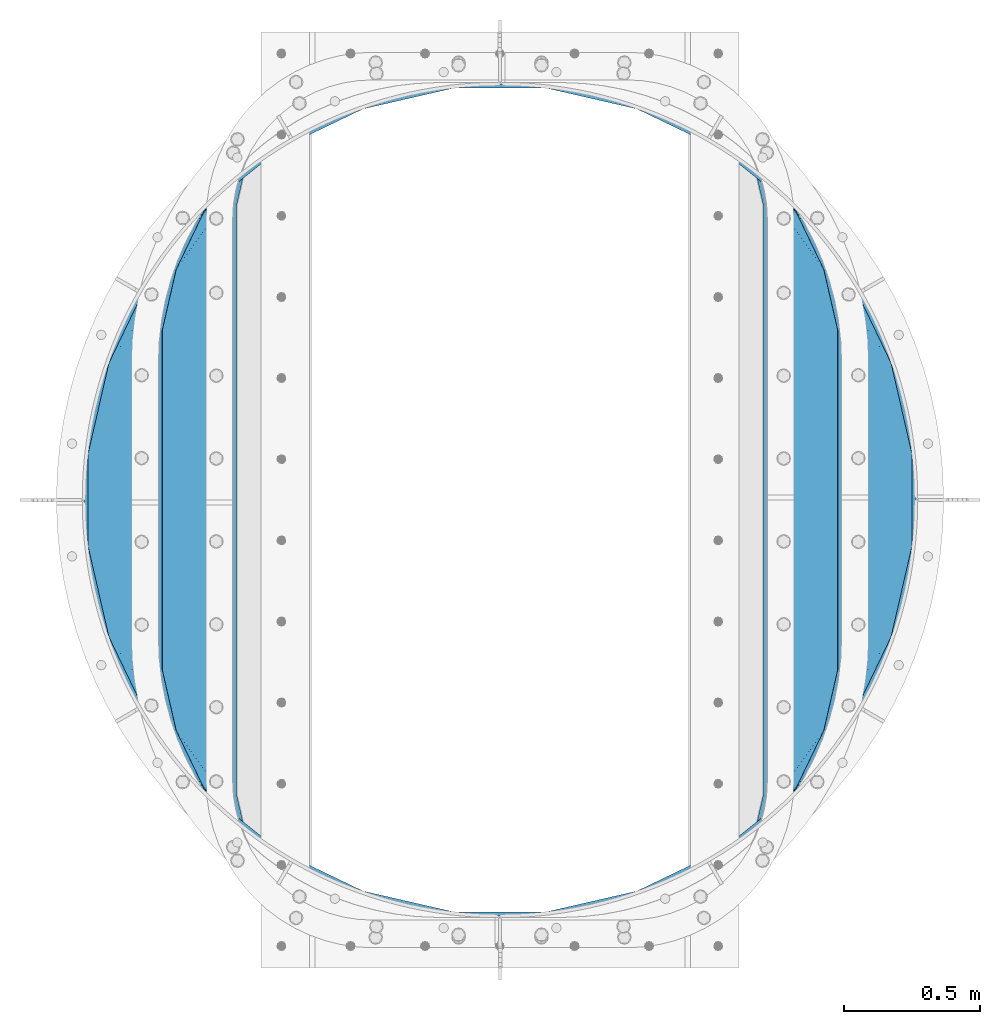
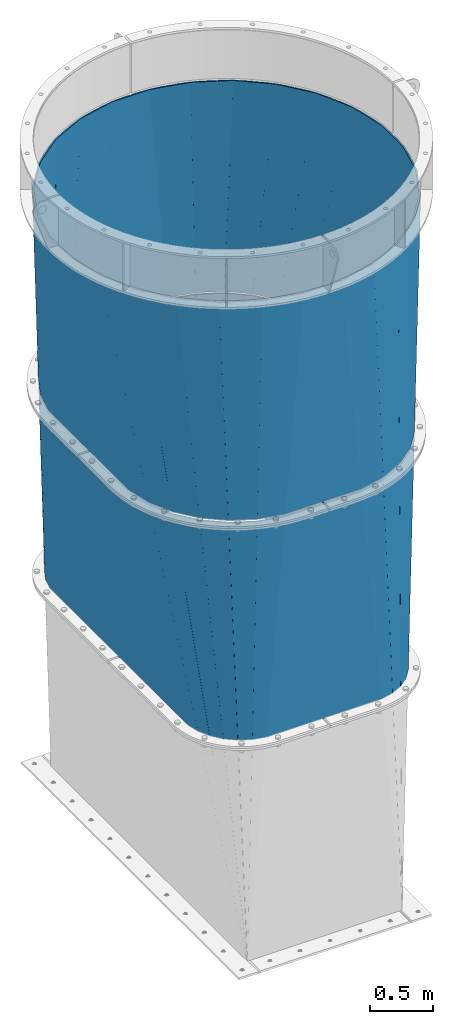
# One storey, part 7 of 15: 2 beams, 2 elements without a shape of their own.
"""IFC2X3 building model written with IfcOpenShell, lengths in millimetres."""

from ifc_helpers import new_model, si_unit, frame, origin_with_axes, place, context, subcontext, project, spatial, faceted_brep, material, type_object, element, aggregate, save


model = new_model("IFC2X3")

# Units and contexts
model_context = context("Model", 3, precision=1e-05, world=origin_with_axes())
body_context = subcontext(model_context, "Body", "Model", "MODEL_VIEW")
ifc_project = project(units=[si_unit("LENGTHUNIT", "METRE", prefix="MILLI"), si_unit("AREAUNIT", "SQUARE_METRE"), si_unit("VOLUMEUNIT", "CUBIC_METRE"), si_unit("MASSUNIT", "GRAM", prefix="KILO"), si_unit("TIMEUNIT", "SECOND"), si_unit("PLANEANGLEUNIT", "RADIAN"), si_unit("SOLIDANGLEUNIT", "STERADIAN"), si_unit("THERMODYNAMICTEMPERATUREUNIT", "DEGREE_CELSIUS"), si_unit("LUMINOUSINTENSITYUNIT", "LUMEN")], contexts=[model_context])

# Site, building, storey
site_placement = place(None, origin_with_axes())
site = spatial("IfcSite", under=ifc_project, at=site_placement, CompositionType="ELEMENT")
building_placement = place(site_placement, origin_with_axes())
building = spatial("IfcBuilding", under=site, at=building_placement, Name="Undefined", CompositionType="ELEMENT")
storey_placement = place(building_placement, origin_with_axes())
storey = spatial("IfcBuildingStorey", under=building, at=storey_placement, Name="Undefined", CompositionType="ELEMENT", Elevation=0.0)

# Assembly, beam
assembly_1_placement = place(storey_placement, origin_with_axes())
assembly_1 = element("IfcElementAssembly", 1, at=assembly_1_placement, inside=storey, Name="TRANSITION", AssemblyPlace="NOTDEFINED", PredefinedType="RIGID_FRAME")
ifc_material = material(Name="STEEL/A36")
beam_type = type_object("IfcBeamType", PredefinedType="NOTDEFINED")
beam_1_placement = place(assembly_1_placement, frame((879.475000000001, 1720.85, 6242.045), z_axis=(1.0, 0.0, 0.0), x_axis=(0.0, 0.0, -1.0)))
beam_1 = element("IfcBeam", 2, at=beam_1_placement, type_object=beam_type, material=ifc_material, Name="TRANSITION", context=body_context, shape_type="Brep", body=[
    faceted_brep([(2069.035, 854.239249285313, 1203.20932660204), (2069.035, 630.620292611843, 1254.49807813265), (4131.73000009537, 1087.72520528114, 982.352835150683), (4131.73000009537, 1200.30381764335, 956.532052498799), (2069.035, 1061.77828739089, 1103.70914863265), (2069.035, 854.571731207215, 1203.20932660204), (4131.73000009537, 1200.96776268595, 956.532052498799), (4131.73000009537, 1305.28372459956, 906.439734154145), (2069.035, 1062.11076931279, 1103.70914863265), (4131.73000009537, 1305.94766964216, 906.439734154145), (2069.035, 1241.62139966993, 960.100644346939), (4131.73000009537, 1396.32040892375, 834.14154272887), (2069.035, 1241.95388159184, 960.100644346939), (4131.73000009537, 1396.98435396635, 834.14154272887), (2069.035, 1385.56238587755, 780.590013989796), (4131.73000009537, 1469.28254539163, 743.768803447277), (2069.035, 1385.56238587755, 779.925050145991), (4131.73000009537, 1469.28254539163, 742.440913362079), (2069.035, 1485.06256384694, 572.718493962317), (4131.73000009537, 1519.37486373628, 638.124951448468), (2069.035, 1485.06256384694, 572.386012040415), (4131.73000009537, 1519.37486373628, 637.461006405869), (2069.035, 1536.35131537755, 348.767055366945), (4131.73000009537, 1545.19564638816, 524.882394043656), (2069.035, 1536.35131537755, -348.767055366945), (4131.73000009537, 1545.19564638816, -524.882394043656), (2069.035, 1485.06256384694, -572.386012040415), (4131.73000009537, 1519.37486373628, -637.461006405869), (2069.035, 1485.06256384694, -573.05097588422), (4131.73000009537, 1519.37486373628, -638.788896491068), (2069.035, 1385.56238587755, -780.257532067893), (4131.73000009537, 1469.28254539163, -743.104858404678), (2069.035, 1385.56238587755, -780.590013989796), (4131.73000009537, 1469.28254539163, -743.768803447277), (2069.035, 1241.95388159184, -960.100644346939), (4131.73000009537, 1396.98435396635, -834.14154272887), (2069.035, 1241.62139966993, -960.100644346939), (4131.73000009537, 1396.32040892375, -834.14154272887), (2069.035, 1062.11076931279, -1103.70914863265), (4131.73000009537, 1305.94766964216, -906.439734154145), (2069.035, 1061.77828739089, -1103.70914863265), (4131.73000009537, 1305.28372459956, -906.439734154145), (2069.035, 854.571731207215, -1203.20932660204), (4131.73000009537, 1200.96776268595, -956.532052498799), (2069.035, 854.239249285313, -1203.20932660204), (4131.73000009537, 1200.30381764335, -956.532052498799), (2069.035, 630.620292611843, -1254.49807813265), (4131.73000009537, 1087.72520528114, -982.352835150683), (2069.035, -630.620292611843, -1254.49807813265), (4131.73000009537, -1087.72520528114, -982.352835150683), (2069.035, -854.239249285313, -1203.20932660204), (4131.73000009537, -1200.30381764335, -956.532052498799), (2069.035, -854.571731207215, -1203.20932660204), (4131.73000009537, -1200.96776268595, -956.532052498799), (2069.035, -1061.77828739089, -1103.70914863265), (4131.73000009537, -1305.28372459956, -906.439734154145), (2069.035, -1062.11076931279, -1103.70914863265), (4131.73000009537, -1305.94766964216, -906.439734154145), (2069.035, -1241.62139966993, -960.100644346939), (4131.73000009537, -1396.32040892375, -834.14154272887), (2069.035, -1241.95388159184, -960.100644346939), (4131.73000009537, -1396.98435396635, -834.14154272887), (2069.035, -1385.56238587755, -780.590013989796), (4131.73000009537, -1469.28254539163, -743.768803447277), (2069.035, -1385.56238587755, -779.925050145991), (4131.73000009537, -1469.28254539163, -742.440913362079), (2069.035, -1485.06256384694, -572.718493962317), (4131.73000009537, -1519.37486373628, -638.124951448468), (2069.035, -1485.06256384694, -572.386012040415), (4131.73000009537, -1519.37486373628, -637.461006405869), (2069.035, -1536.35131537755, -348.767055366945), (4131.73000009537, -1545.19564638816, -524.882394043656), (2069.035, -1536.35131537755, 348.767055366945), (4131.73000009537, -1545.19564638816, 524.882394043656), (2069.035, -1485.06256384694, 572.386012040415), (4131.73000009537, -1519.37486373628, 637.461006405869), (2069.035, -1485.06256384694, 573.05097588422), (4131.73000009537, -1519.37486373628, 638.788896491068), (2069.035, -1385.56238587755, 780.257532067893), (4131.73000009537, -1469.28254539163, 743.104858404678), (2069.035, -1385.56238587755, 780.590013989796), (4131.73000009537, -1469.28254539163, 743.768803447277), (2069.035, -1241.95388159184, 960.100644346939), (4131.73000009537, -1396.98435396635, 834.14154272887), (2069.035, -1241.62139966993, 960.100644346939), (4131.73000009537, -1396.32040892375, 834.14154272887), (2069.035, -1062.11076931279, 1103.70914863265), (4131.73000009537, -1305.94766964216, 906.439734154145), (2069.035, -1061.77828739089, 1103.70914863265), (4131.73000009537, -1305.28372459956, 906.439734154145), (2069.035, -854.571731207215, 1203.20932660204), (4131.73000009537, -1200.96776268595, 956.532052498799), (2069.035, -854.239249285313, 1203.20932660204), (4131.73000009537, -1200.30381764335, 956.532052498799), (2069.035, -630.620292611843, 1254.49807813265), (4131.73000009537, -1087.72520528114, 982.352835150683), (2069.035, -847.551642533746, 1190.98406545918), (2069.035, -1053.04574783987, 1092.3062030102), (2069.035, -1053.37822976177, 1092.3062030102), (2069.035, -1231.40530119034, 949.884545867347), (2069.035, -1231.73778311224, 949.884545867347), (2069.035, -1374.1594402551, 771.857474438776), (2069.035, -1374.1594402551, 771.19251059497), (2069.035, -1472.83730270408, 565.698405288848), (2069.035, -1472.83730270408, 565.365923366945), (2069.035, -1523.7021802551, 343.595057244496), (2069.035, -1523.7021802551, -343.595057244496), (2069.035, -1472.83730270408, -565.365923366945), (2069.035, -1472.83730270408, -566.03088721075), (2069.035, -1374.1594402551, -771.524992516873), (2069.035, -1374.1594402551, -771.857474438776), (2069.035, -1231.73778311224, -949.884545867347), (2069.035, -1231.40530119034, -949.884545867347), (2069.035, -1053.37822976177, -1092.3062030102), (2069.035, -1053.04574783987, -1092.3062030102), (2069.035, -847.551642533746, -1190.98406545918), (2069.035, -847.219160611843, -1190.98406545918), (2069.035, -625.448294489394, -1241.8489430102), (2069.035, 625.448294489394, -1241.8489430102), (2069.035, 847.219160611843, -1190.98406545918), (2069.035, 847.551642533746, -1190.98406545918), (2069.035, 1053.04574783987, -1092.3062030102), (2069.035, 1053.37822976177, -1092.3062030102), (2069.035, 1231.40530119034, -949.884545867347), (2069.035, 1231.73778311225, -949.884545867347), (2069.035, 1374.1594402551, -771.857474438776), (2069.035, 1374.1594402551, -771.19251059497), (2069.035, 1472.83730270408, -565.698405288848), (2069.035, 1472.83730270408, -565.365923366945), (2069.035, 1523.7021802551, -343.595057244496), (2069.035, 1523.7021802551, 343.595057244496), (2069.035, 1472.83730270408, 565.365923366945), (2069.035, 1472.83730270408, 566.03088721075), (2069.035, 1374.1594402551, 771.524992516873), (2069.035, 1374.1594402551, 771.857474438776), (2069.035, 1231.73778311225, 949.884545867347), (2069.035, 1231.40530119034, 949.884545867347), (2069.035, 1053.37822976177, 1092.3062030102), (2069.035, 1053.04574783987, 1092.3062030102), (2069.035, 847.551642533746, 1190.98406545918), (2069.035, 847.219160611843, 1190.98406545918), (2069.035, 625.448294489394, 1241.8489430102), (2069.035, -625.448294489394, 1241.8489430102), (2069.035, -847.219160611843, 1190.98406545918), (4131.73000009537, -1078.81509866872, 969.678442538437), (4131.73000009537, -1190.46330927587, 944.071054784503), (4131.73000009537, -1191.12725431847, 944.071054784503), (4131.73000009537, -1294.58110084437, 894.39272254187), (4131.73000009537, -1295.24504588697, 894.39272254187), (4131.73000009537, -1384.87090302574, 822.692036830854), (4131.73000009537, -1385.53484806834, 822.692036830854), (4131.73000009537, -1457.23553377935, 733.066179692084), (4131.73000009537, -1457.23553377935, 731.738289606885), (4131.73000009537, -1506.91386602198, 628.284443080991), (4131.73000009537, -1506.91386602198, 627.620498038392), (4131.73000009537, -1532.52125377592, 515.972287431238), (4131.73000009537, -1532.52125377592, -515.972287431238), (4131.73000009537, -1506.91386602198, -627.620498038392), (4131.73000009537, -1506.91386602198, -628.94838812359), (4131.73000009537, -1457.23553377935, -732.402234649485), (4131.73000009537, -1457.23553377935, -733.066179692084), (4131.73000009537, -1385.53484806834, -822.692036830854), (4131.73000009537, -1384.87090302574, -822.692036830854), (4131.73000009537, -1295.24504588697, -894.39272254187), (4131.73000009537, -1294.58110084437, -894.39272254187), (4131.73000009537, -1191.12725431847, -944.071054784503), (4131.73000009537, -1190.46330927587, -944.071054784503), (4131.73000009537, -1078.81509866872, -969.678442538437), (4131.73000009537, 1078.81509866872, -969.678442538437), (4131.73000009537, 1190.46330927587, -944.071054784503), (4131.73000009537, 1191.12725431847, -944.071054784503), (4131.73000009537, 1294.58110084437, -894.39272254187), (4131.73000009537, 1295.24504588697, -894.39272254187), (4131.73000009537, 1384.87090302574, -822.692036830854), (4131.73000009537, 1385.53484806834, -822.692036830854), (4131.73000009537, 1457.23553377935, -733.066179692084), (4131.73000009537, 1457.23553377935, -731.738289606885), (4131.73000009537, 1506.91386602198, -628.284443080991), (4131.73000009537, 1506.91386602198, -627.620498038392), (4131.73000009537, 1532.52125377592, -515.972287431238), (4131.73000009537, 1532.52125377592, 515.972287431238), (4131.73000009537, 1506.91386602198, 627.620498038392), (4131.73000009537, 1506.91386602198, 628.94838812359), (4131.73000009537, 1457.23553377935, 732.402234649485), (4131.73000009537, 1457.23553377935, 733.066179692084), (4131.73000009537, 1385.53484806834, 822.692036830854), (4131.73000009537, 1384.87090302574, 822.692036830854), (4131.73000009537, 1295.24504588697, 894.39272254187), (4131.73000009537, 1294.58110084437, 894.39272254187), (4131.73000009537, 1191.12725431847, 944.071054784503), (4131.73000009537, 1190.46330927587, 944.071054784503), (4131.73000009537, 1078.81509866872, 969.678442538437)], [[[0, 1, 2, 3]], [[4, 5, 6, 7]], [[8, 4, 7, 9]], [[10, 8, 9, 11]], [[12, 10, 11, 13]], [[14, 12, 13, 15]], [[16, 14, 15, 17]], [[18, 16, 17, 19]], [[20, 18, 19, 21]], [[22, 20, 21, 23]], [[24, 22, 23, 25]], [[26, 24, 25, 27]], [[28, 26, 27, 29]], [[30, 28, 29, 31]], [[32, 30, 31, 33]], [[34, 32, 33, 35]], [[36, 34, 35, 37]], [[38, 36, 37, 39]], [[40, 38, 39, 41]], [[42, 40, 41, 43]], [[44, 42, 43, 45]], [[46, 44, 45, 47]], [[48, 46, 47, 49]], [[50, 48, 49, 51]], [[52, 50, 51, 53]], [[54, 52, 53, 55]], [[56, 54, 55, 57]], [[58, 56, 57, 59]], [[60, 58, 59, 61]], [[62, 60, 61, 63]], [[64, 62, 63, 65]], [[66, 64, 65, 67]], [[68, 66, 67, 69]], [[70, 68, 69, 71]], [[72, 70, 71, 73]], [[74, 72, 73, 75]], [[76, 74, 75, 77]], [[78, 76, 77, 79]], [[80, 78, 79, 81]], [[82, 80, 81, 83]], [[84, 82, 83, 85]], [[86, 84, 85, 87]], [[88, 86, 87, 89]], [[90, 88, 89, 91]], [[92, 90, 91, 93]], [[94, 92, 93, 95]], [[1, 94, 95, 2]], [[0, 5, 4, 8, 10, 12, 14, 16, 18, 20, 22, 24, 26, 28, 30, 32, 34, 36, 38, 40, 42, 44, 46, 48, 50, 52, 54, 56, 58, 60, 62, 64, 66, 68, 70, 72, 74, 76, 78, 80, 82, 84, 86, 88, 90, 92, 94, 1], [96, 97, 98, 99, 100, 101, 102, 103, 104, 105, 106, 107, 108, 109, 110, 111, 112, 113, 114, 115, 116, 117, 118, 119, 120, 121, 122, 123, 124, 125, 126, 127, 128, 129, 130, 131, 132, 133, 134, 135, 136, 137, 138, 139, 140, 141, 142, 143]], [[143, 142, 144, 145]], [[96, 143, 145, 146]], [[97, 96, 146, 147]], [[98, 97, 147, 148]], [[99, 98, 148, 149]], [[100, 99, 149, 150]], [[101, 100, 150, 151]], [[102, 101, 151, 152]], [[103, 102, 152, 153]], [[104, 103, 153, 154]], [[105, 104, 154, 155]], [[106, 105, 155, 156]], [[107, 106, 156, 157]], [[108, 107, 157, 158]], [[109, 108, 158, 159]], [[110, 109, 159, 160]], [[111, 110, 160, 161]], [[112, 111, 161, 162]], [[113, 112, 162, 163]], [[114, 113, 163, 164]], [[115, 114, 164, 165]], [[116, 115, 165, 166]], [[117, 116, 166, 167]], [[118, 117, 167, 168]], [[119, 118, 168, 169]], [[120, 119, 169, 170]], [[121, 120, 170, 171]], [[122, 121, 171, 172]], [[123, 122, 172, 173]], [[124, 123, 173, 174]], [[125, 124, 174, 175]], [[126, 125, 175, 176]], [[127, 126, 176, 177]], [[128, 127, 177, 178]], [[129, 128, 178, 179]], [[130, 129, 179, 180]], [[131, 130, 180, 181]], [[132, 131, 181, 182]], [[133, 132, 182, 183]], [[134, 133, 183, 184]], [[135, 134, 184, 185]], [[136, 135, 185, 186]], [[137, 136, 186, 187]], [[138, 137, 187, 188]], [[139, 138, 188, 189]], [[140, 139, 189, 190]], [[141, 140, 190, 191]], [[142, 141, 191, 144]], [[91, 89, 87, 85, 83, 81, 79, 77, 75, 73, 71, 69, 67, 65, 63, 61, 59, 57, 55, 53, 51, 49, 47, 45, 43, 41, 39, 37, 35, 33, 31, 29, 27, 25, 23, 21, 19, 17, 15, 13, 11, 9, 7, 6, 3, 2, 95, 93], [190, 189, 188, 187, 186, 185, 184, 183, 182, 181, 180, 179, 178, 177, 176, 175, 174, 173, 172, 171, 170, 169, 168, 167, 166, 165, 164, 163, 162, 161, 160, 159, 158, 157, 156, 155, 154, 153, 152, 151, 150, 149, 148, 147, 146, 145, 144, 191]], [[5, 0, 3, 6]]]),
])
aggregate(assembly_1, [beam_1])

assembly_2_placement = place(storey_placement, origin_with_axes())
assembly_2 = element("IfcElementAssembly", 3, at=assembly_2_placement, inside=storey, Name="TRANSITION", AssemblyPlace="NOTDEFINED", PredefinedType="RIGID_FRAME")
beam_2_placement = place(assembly_2_placement, frame((879.47499999973, 1720.85, 6264.28), z_axis=(1.0, 0.0, 0.0), x_axis=(0.0, 0.0, -1.0)))
beam_2 = element("IfcBeam", 4, at=beam_2_placement, type_object=beam_type, material=ifc_material, Name="TRANSITION", context=body_context, shape_type="Brep", body=[
    faceted_brep([(0.0, 817.5244, -1301.5849), (0.0, 1086.4469, -1086.4469), (2072.21999980927, 1241.30694938853, -960.356676206096), (2072.21999980927, 1061.61513212484, -1104.11013001705), (2072.21999980927, 1061.28332395432, -1104.11013001705), (0.0, 507.111, -1450.6448), (2072.21999980927, 853.867626312808, -1203.71073730035), (2072.21999980927, 853.53581814229, -1203.71073730035), (0.0, 172.1104, -1527.4798), (2072.21999980927, 629.691154350952, -1255.05125651855), (0.0, -172.1104, -1527.4798), (2072.21999980927, -629.691154350952, -1255.05125651855), (0.0, -507.111, -1450.6448), (2072.21999980927, -853.53581814229, -1203.71073730035), (2072.21999980927, -853.867626312809, -1203.71073730035), (0.0, -817.5244, -1301.5849), (2072.21999980927, -1061.28332395432, -1104.11013001705), (2072.21999980927, -1061.61513212484, -1104.11013001705), (0.0, -1086.4469, -1086.4469), (2072.21999980927, -1241.30694938853, -960.356676206096), (2072.21999980927, -1241.63875755905, -960.356676206096), (0.0, -1301.5849, -817.5244), (2072.21999980927, -1385.39221137, -780.664858942408), (2072.21999980927, -1385.39221137, -780.00124260137), (0.0, -1450.6448, -507.111), (2072.21999980927, -1484.9928186533, -572.585544959855), (2072.21999980927, -1484.9928186533, -572.253736789337), (0.0, -1527.4798, -172.1104), (2072.21999980927, -1536.3333378715, -348.409072997999), (0.0, -1527.4798, 172.1104), (2072.21999980927, -1536.3333378715, 348.409072997999), (0.0, -1450.6448, 507.111), (2072.21999980927, -1484.9928186533, 572.253736789337), (2072.21999980927, -1484.9928186533, 572.917353130374), (0.0, -1301.5849, 817.5244), (2072.21999980927, -1385.39221137, 780.333050771889), (2072.21999980927, -1385.39221137, 780.664858942408), (0.0, -1086.4469, 1086.4469), (2072.21999980927, -1241.63875755905, 960.356676206096), (2072.21999980927, -1241.30694938853, 960.356676206096), (0.0, -817.5244, 1301.5849), (2072.21999980927, -1061.61513212484, 1104.11013001705), (2072.21999980927, -1061.28332395432, 1104.11013001705), (0.0, -507.111, 1450.6448), (2072.21999980927, -853.867626312809, 1203.71073730035), (2072.21999980927, -853.53581814229, 1203.71073730035), (0.0, -172.1104, 1527.4798), (2072.21999980927, -629.691154350952, 1255.05125651855), (0.0, 172.1104, 1527.4798), (2072.21999980927, 629.691154350952, 1255.05125651855), (0.0, 507.111, 1450.6448), (2072.21999980927, 853.53581814229, 1203.71073730035), (2072.21999980927, 853.867626312808, 1203.71073730035), (0.0, 817.5244, 1301.5849), (2072.21999980927, 1061.28332395432, 1104.11013001705), (2072.21999980927, 1061.61513212484, 1104.11013001705), (0.0, 1086.4469, 1086.4469), (2072.21999980927, 1241.30694938853, 960.356676206096), (2072.21999980927, 1241.63875755905, 960.356676206096), (0.0, 1301.5849, 817.5244), (2072.21999980927, 1385.39221137, 780.664858942408), (2072.21999980927, 1385.39221137, 780.001242601371), (0.0, 1450.6448, 507.111), (2072.21999980927, 1484.9928186533, 572.585544959855), (2072.21999980927, 1484.9928186533, 572.253736789337), (0.0, 1527.4798, 172.1104), (2072.21999980927, 1536.3333378715, 348.409072997999), (0.0, 1527.4798, -172.1104), (2072.21999980927, 1536.3333378715, -348.409072997999), (0.0, 1450.6448, -507.111), (2072.21999980927, 1484.9928186533, -572.253736789337), (2072.21999980927, 1484.9928186533, -572.917353130374), (0.0, 1301.5849, -817.5244), (2072.21999980927, 1385.39221137, -780.333050771889), (2072.21999980927, 1385.39221137, -780.664858942408), (2072.21999980927, 1241.63875755905, -960.356676206096), (0.0, 1290.828, -810.768), (0.0, 1438.656, -502.92), (0.0, 1514.856, -170.688), (0.0, 1514.856, 170.688), (0.0, 1438.656, 502.92), (0.0, 1290.828, 810.768), (0.0, 1077.468, 1077.468), (0.0, 810.768, 1290.828), (0.0, 502.92, 1438.656), (0.0, 170.688, 1514.856), (0.0, -170.688, 1514.856), (0.0, -502.92, 1438.656), (0.0, -810.768, 1290.828), (0.0, -1077.468, 1077.468), (0.0, -1290.828, 810.768), (0.0, -1438.656, 502.92), (0.0, -1514.856, 170.688), (0.0, -1514.856, -170.688), (0.0, -1438.656, -502.92), (0.0, -1290.828, -810.768), (0.0, -1077.468, -1077.468), (0.0, -810.768, -1290.828), (0.0, -502.92, -1438.656), (0.0, -170.688, -1514.856), (0.0, 170.688, -1514.856), (0.0, 502.92, -1438.656), (0.0, 810.768, -1290.828), (0.0, 1077.468, -1077.468), (2072.21999980927, -624.526754527111, 1242.40217273595), (2072.21999980927, -846.521462419346, 1191.48595532948), (2072.21999980927, -846.853270589865, 1191.48595532948), (2072.21999980927, -1052.55478891203, 1092.70849356091), (2072.21999980927, -1052.88659708255, 1092.70849356091), (2072.21999980927, -1231.09335800521, 950.143084822779), (2072.21999980927, -1231.42516617573, 950.143084822779), (2072.21999980927, -1373.99057491387, 771.936323900113), (2072.21999980927, -1373.99057491387, 771.272707559076), (2072.21999980927, -1472.76803668243, 565.571189236912), (2072.21999980927, -1472.76803668243, 565.239381066393), (2072.21999980927, -1523.68425408891, 343.244673174157), (2072.21999980927, -1523.68425408891, -343.244673174157), (2072.21999980927, -1472.76803668243, -565.239381066393), (2072.21999980927, -1472.76803668243, -565.902997407431), (2072.21999980927, -1373.99057491387, -771.604515729594), (2072.21999980927, -1373.99057491387, -771.936323900113), (2072.21999980927, -1231.42516617573, -950.143084822779), (2072.21999980927, -1231.09335800521, -950.143084822779), (2072.21999980927, -1052.88659708255, -1092.70849356091), (2072.21999980927, -1052.55478891203, -1092.70849356091), (2072.21999980927, -846.853270589865, -1191.48595532948), (2072.21999980927, -846.521462419346, -1191.48595532948), (2072.21999980927, -624.526754527111, -1242.40217273595), (2072.21999980927, 624.526754527111, -1242.40217273595), (2072.21999980927, 846.521462419347, -1191.48595532948), (2072.21999980927, 846.853270589865, -1191.48595532948), (2072.21999980927, 1052.55478891203, -1092.70849356091), (2072.21999980927, 1052.88659708255, -1092.70849356091), (2072.21999980927, 1231.09335800521, -950.143084822779), (2072.21999980927, 1231.42516617573, -950.143084822779), (2072.21999980927, 1373.99057491387, -771.936323900113), (2072.21999980927, 1373.99057491387, -771.272707559076), (2072.21999980927, 1472.76803668243, -565.571189236912), (2072.21999980927, 1472.76803668243, -565.239381066393), (2072.21999980927, 1523.68425408891, -343.244673174157), (2072.21999980927, 1523.68425408891, 343.244673174157), (2072.21999980927, 1472.76803668243, 565.239381066393), (2072.21999980927, 1472.76803668243, 565.902997407431), (2072.21999980927, 1373.99057491387, 771.604515729594), (2072.21999980927, 1373.99057491387, 771.936323900113), (2072.21999980927, 1231.42516617573, 950.143084822779), (2072.21999980927, 1231.09335800521, 950.143084822779), (2072.21999980927, 1052.88659708255, 1092.70849356091), (2072.21999980927, 1052.55478891203, 1092.70849356091), (2072.21999980927, 846.853270589865, 1191.48595532948), (2072.21999980927, 846.521462419347, 1191.48595532948), (2072.21999980927, 624.526754527111, 1242.40217273595)], [[[0, 1, 2, 3]], [[0, 3, 4]], [[5, 0, 4, 6]], [[5, 6, 7]], [[8, 5, 7, 9]], [[10, 8, 9, 11]], [[12, 10, 11, 13]], [[12, 13, 14]], [[15, 12, 14, 16]], [[15, 16, 17]], [[18, 15, 17, 19]], [[18, 19, 20]], [[21, 18, 20, 22]], [[21, 22, 23]], [[24, 21, 23, 25]], [[24, 25, 26]], [[27, 24, 26, 28]], [[29, 27, 28, 30]], [[31, 29, 30, 32]], [[31, 32, 33]], [[34, 31, 33, 35]], [[34, 35, 36]], [[37, 34, 36, 38]], [[37, 38, 39]], [[40, 37, 39, 41]], [[40, 41, 42]], [[43, 40, 42, 44]], [[43, 44, 45]], [[46, 43, 45, 47]], [[48, 46, 47, 49]], [[50, 48, 49, 51]], [[50, 51, 52]], [[53, 50, 52, 54]], [[53, 54, 55]], [[56, 53, 55, 57]], [[56, 57, 58]], [[59, 56, 58, 60]], [[59, 60, 61]], [[62, 59, 61, 63]], [[62, 63, 64]], [[65, 62, 64, 66]], [[67, 65, 66, 68]], [[69, 67, 68, 70]], [[69, 70, 71]], [[72, 69, 71, 73]], [[72, 73, 74]], [[1, 72, 74, 75]], [[0, 5, 8, 10, 12, 15, 18, 21, 24, 27, 29, 31, 34, 37, 40, 43, 46, 48, 50, 53, 56, 59, 62, 65, 67, 69, 72, 1], [76, 77, 78, 79, 80, 81, 82, 83, 84, 85, 86, 87, 88, 89, 90, 91, 92, 93, 94, 95, 96, 97, 98, 99, 100, 101, 102, 103]], [[87, 86, 104, 105]], [[87, 105, 106]], [[88, 87, 106, 107]], [[88, 107, 108]], [[89, 88, 108, 109]], [[89, 109, 110]], [[90, 89, 110, 111]], [[90, 111, 112]], [[91, 90, 112, 113]], [[91, 113, 114]], [[92, 91, 114, 115]], [[93, 92, 115, 116]], [[94, 93, 116, 117]], [[94, 117, 118]], [[95, 94, 118, 119]], [[95, 119, 120]], [[96, 95, 120, 121]], [[96, 121, 122]], [[97, 96, 122, 123]], [[97, 123, 124]], [[98, 97, 124, 125]], [[98, 125, 126]], [[99, 98, 126, 127]], [[100, 99, 127, 128]], [[101, 100, 128, 129]], [[101, 129, 130]], [[102, 101, 130, 131]], [[102, 131, 132]], [[103, 102, 132, 133]], [[103, 133, 134]], [[76, 103, 134, 135]], [[76, 135, 136]], [[77, 76, 136, 137]], [[77, 137, 138]], [[78, 77, 138, 139]], [[79, 78, 139, 140]], [[80, 79, 140, 141]], [[80, 141, 142]], [[81, 80, 142, 143]], [[81, 143, 144]], [[82, 81, 144, 145]], [[82, 145, 146]], [[83, 82, 146, 147]], [[83, 147, 148]], [[84, 83, 148, 149]], [[84, 149, 150]], [[85, 84, 150, 151]], [[86, 85, 151, 104]], [[44, 42, 41, 39, 38, 36, 35, 33, 32, 30, 28, 26, 25, 23, 22, 20, 19, 17, 16, 14, 13, 11, 9, 7, 6, 4, 3, 2, 75, 74, 73, 71, 70, 68, 66, 64, 63, 61, 60, 58, 57, 55, 54, 52, 51, 49, 47, 45], [150, 149, 148, 147, 146, 145, 144, 143, 142, 141, 140, 139, 138, 137, 136, 135, 134, 133, 132, 131, 130, 129, 128, 127, 126, 125, 124, 123, 122, 121, 120, 119, 118, 117, 116, 115, 114, 113, 112, 111, 110, 109, 108, 107, 106, 105, 104, 151]], [[1, 75, 2]]]),
])
aggregate(assembly_2, [beam_2])

save(model, "model.ifc")
